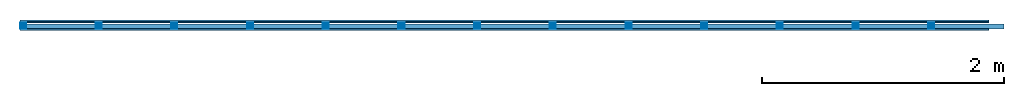
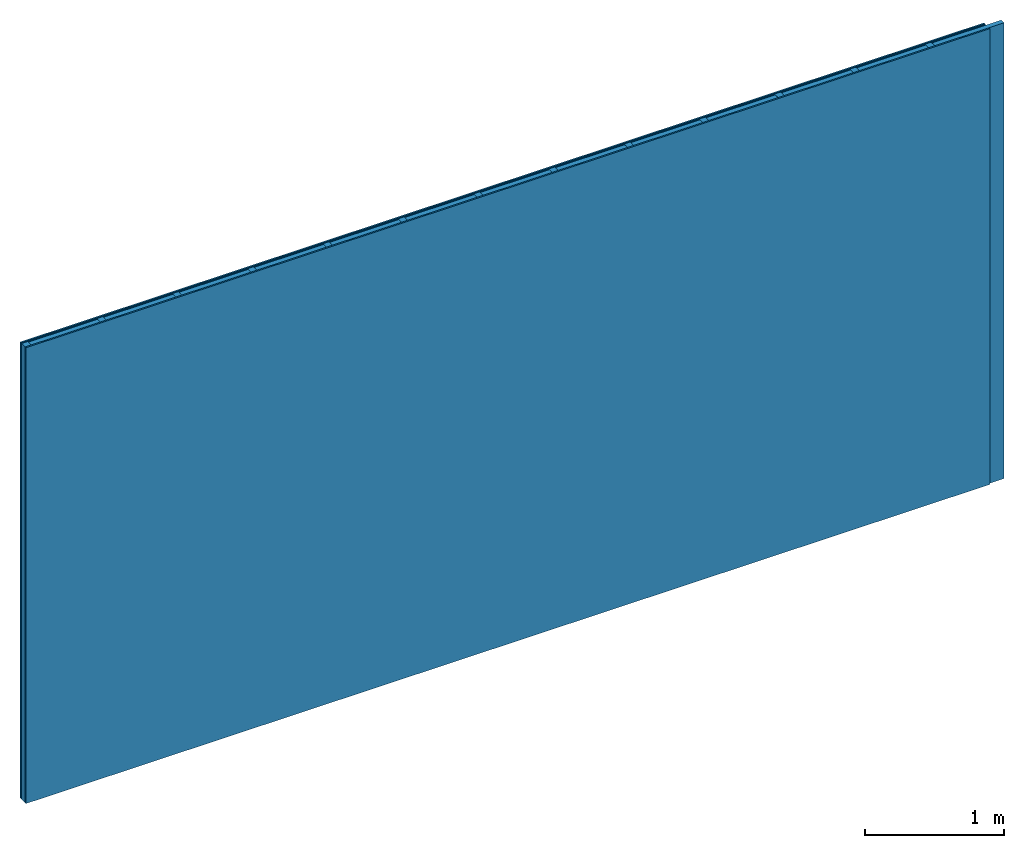
# One storey: 3 plates, 2 members, 1 element without a shape of its own.
"""IFC4 building model written with IfcOpenShell, lengths in metres."""

from ifc_helpers import new_model, si_unit, derived_unit, direction, frame, frame_2d, origin, origin_with_axes, place, context, project, spatial, rectangle, extrude, material, layer, layer_set, type_object, element, aggregate, save


model = new_model("IFC4")

# Units and contexts
plan_context = context("Plan", 3, precision=1e-05, world=origin(), true_north=direction((0.0, 1.0)))
model_context = context("Model", 3, precision=1e-05, world=origin(), true_north=direction((0.0, 1.0)))
ifc_project = project(units=[si_unit("LENGTHUNIT", "METRE"), derived_unit("SOUNDPRESSUREUNIT", [(si_unit("PRESSUREUNIT", "PASCAL", prefix="MICRO"), 0)]), si_unit("ENERGYUNIT", "JOULE", prefix="MEGA"), si_unit("MASSUNIT", "GRAM", prefix="KILO"), derived_unit("THERMALTRANSMITTANCEUNIT", [(si_unit("POWERUNIT", "WATT"), 1), (si_unit("AREAUNIT", "SQUARE_METRE"), -1), (si_unit("THERMODYNAMICTEMPERATUREUNIT", "KELVIN"), -1)]), derived_unit("AREADENSITYUNIT", [(si_unit("MASSUNIT", "GRAM", prefix="KILO"), 1), (si_unit("AREAUNIT", "SQUARE_METRE"), -1)]), derived_unit("USERDEFINED", [(si_unit("ENERGYUNIT", "JOULE", prefix="MEGA"), 1), (si_unit("AREAUNIT", "SQUARE_METRE"), -1)])], contexts=[plan_context, model_context])

# Site, building, storey
site = spatial("IfcSite", under=ifc_project)
building_placement = place(None, origin())
building = spatial("IfcBuilding", under=site, at=building_placement)
storey_placement = place(building_placement, origin())
storey = spatial("IfcBuildingStorey", under=building, at=storey_placement)

# Wall, members, plates
ifc_material_1 = material(Name="joints", Category="04.017")
ifc_layer_1 = layer(ifc_material_1, 0.0, Name="Surface")
ifc_material_2 = material(Name="Plasterboard type A", Category="03.008")
ifc_layer_2 = layer(ifc_material_2, 0.0125, Name="2nd layer")
ifc_material_3 = material(Name="Phone Twin Star", Category="03.013")
ifc_layer_3 = layer(ifc_material_3, 0.01, Name="1st layer")
ifc_material_4 = material(Name="of the art")
ifc_layer_4 = layer(ifc_material_4, 0.0, Name="Bond")
ifc_layer_5 = layer(None, 0.05, Name="Support")
ifc_layer_6 = layer(ifc_material_4, 0.0, Name="Bond")
ifc_layer_7 = layer(ifc_material_2, 0.0125, Name="1st layer")
ifc_layer_8 = layer(ifc_material_1, 0.0, Name="Surface")
ifc_layer_set = layer_set([ifc_layer_1, ifc_layer_2, ifc_layer_3, ifc_layer_4, ifc_layer_5, ifc_layer_6, ifc_layer_7, ifc_layer_8])
wall_type = type_object("IfcWallType", Name="C0457", PredefinedType="NOTDEFINED", material=ifc_layer_set)
wall_placement = place(None, frame((0.0, 0.0, 0.0), z_axis=(0.0, -1.0, 0.0), x_axis=(1.0, 0.0, 0.0)))
wall = element("IfcWall", 1, at=wall_placement, inside=storey, type_object=wall_type, material=ifc_layer_set, Name="Wall #1")
ifc_material_5 = material()
member_1_placement = place(wall_placement, origin())
member_1 = element("IfcMember", 2, at=member_1_placement, material=ifc_material_5, Name="Support", context=plan_context, shape_type="SweptSolid", body=[
    extrude(rectangle(XDim=0.05, YDim=0.05, at=frame_2d((0.025, 0.025), x_axis=(1.0, 0.0))), frame((0.0, 4.0, 0.0225), z_axis=(0.0, -1.0, 0.0), x_axis=(1.0, 0.0, 0.0)), (0.0, 0.0, 1.0), 4.0),
    extrude(rectangle(XDim=0.05, YDim=0.05, at=frame_2d((0.025, 0.025), x_axis=(1.0, 0.0))), frame((0.625, 4.0, 0.0225), z_axis=(0.0, -1.0, 0.0), x_axis=(1.0, 0.0, 0.0)), (0.0, 0.0, 1.0), 4.0),
    extrude(rectangle(XDim=0.05, YDim=0.05, at=frame_2d((0.025, 0.025), x_axis=(1.0, 0.0))), frame((1.25, 4.0, 0.0225), z_axis=(0.0, -1.0, 0.0), x_axis=(1.0, 0.0, 0.0)), (0.0, 0.0, 1.0), 4.0),
    extrude(rectangle(XDim=0.05, YDim=0.05, at=frame_2d((0.025, 0.025), x_axis=(1.0, 0.0))), frame((1.875, 4.0, 0.0225), z_axis=(0.0, -1.0, 0.0), x_axis=(1.0, 0.0, 0.0)), (0.0, 0.0, 1.0), 4.0),
    extrude(rectangle(XDim=0.05, YDim=0.05, at=frame_2d((0.025, 0.025), x_axis=(1.0, 0.0))), frame((2.5, 4.0, 0.0225), z_axis=(0.0, -1.0, 0.0), x_axis=(1.0, 0.0, 0.0)), (0.0, 0.0, 1.0), 4.0),
    extrude(rectangle(XDim=0.05, YDim=0.05, at=frame_2d((0.025, 0.025), x_axis=(1.0, 0.0))), frame((3.125, 4.0, 0.0225), z_axis=(0.0, -1.0, 0.0), x_axis=(1.0, 0.0, 0.0)), (0.0, 0.0, 1.0), 4.0),
    extrude(rectangle(XDim=0.05, YDim=0.05, at=frame_2d((0.025, 0.025), x_axis=(1.0, 0.0))), frame((3.75, 4.0, 0.0225), z_axis=(0.0, -1.0, 0.0), x_axis=(1.0, 0.0, 0.0)), (0.0, 0.0, 1.0), 4.0),
    extrude(rectangle(XDim=0.05, YDim=0.05, at=frame_2d((0.025, 0.025), x_axis=(1.0, 0.0))), frame((4.375, 4.0, 0.0225), z_axis=(0.0, -1.0, 0.0), x_axis=(1.0, 0.0, 0.0)), (0.0, 0.0, 1.0), 4.0),
    extrude(rectangle(XDim=0.05, YDim=0.05, at=frame_2d((0.025, 0.025), x_axis=(1.0, 0.0))), frame((5.0, 4.0, 0.0225), z_axis=(0.0, -1.0, 0.0), x_axis=(1.0, 0.0, 0.0)), (0.0, 0.0, 1.0), 4.0),
    extrude(rectangle(XDim=0.05, YDim=0.05, at=frame_2d((0.025, 0.025), x_axis=(1.0, 0.0))), frame((5.625, 4.0, 0.0225), z_axis=(0.0, -1.0, 0.0), x_axis=(1.0, 0.0, 0.0)), (0.0, 0.0, 1.0), 4.0),
    extrude(rectangle(XDim=0.05, YDim=0.05, at=frame_2d((0.025, 0.025), x_axis=(1.0, 0.0))), frame((6.25, 4.0, 0.0225), z_axis=(0.0, -1.0, 0.0), x_axis=(1.0, 0.0, 0.0)), (0.0, 0.0, 1.0), 4.0),
    extrude(rectangle(XDim=0.05, YDim=0.05, at=frame_2d((0.025, 0.025), x_axis=(1.0, 0.0))), frame((6.875, 4.0, 0.0225), z_axis=(0.0, -1.0, 0.0), x_axis=(1.0, 0.0, 0.0)), (0.0, 0.0, 1.0), 4.0),
    extrude(rectangle(XDim=0.05, YDim=0.05, at=frame_2d((0.025, 0.025), x_axis=(1.0, 0.0))), frame((7.5, 4.0, 0.0225), z_axis=(0.0, -1.0, 0.0), x_axis=(1.0, 0.0, 0.0)), (0.0, 0.0, 1.0), 4.0),
])
ifc_material_6 = material()
member_2_placement = place(wall_placement, origin())
member_2 = element("IfcMember", 3, at=member_2_placement, material=ifc_material_6, Name="Cavity", context=plan_context, shape_type="SweptSolid", body=[
    extrude(rectangle(XDim=0.575, YDim=0.04, at=frame_2d((0.2875, 0.02), x_axis=(1.0, 0.0))), frame((0.05, 4.0, 0.0325), z_axis=(0.0, -1.0, 0.0), x_axis=(1.0, 0.0, 0.0)), (0.0, 0.0, 1.0), 4.0),
    extrude(rectangle(XDim=0.575, YDim=0.04, at=frame_2d((0.2875, 0.02), x_axis=(1.0, 0.0))), frame((0.675, 4.0, 0.0325), z_axis=(0.0, -1.0, 0.0), x_axis=(1.0, 0.0, 0.0)), (0.0, 0.0, 1.0), 4.0),
    extrude(rectangle(XDim=0.575, YDim=0.04, at=frame_2d((0.2875, 0.02), x_axis=(1.0, 0.0))), frame((1.3, 4.0, 0.0325), z_axis=(0.0, -1.0, 0.0), x_axis=(1.0, 0.0, 0.0)), (0.0, 0.0, 1.0), 4.0),
    extrude(rectangle(XDim=0.575, YDim=0.04, at=frame_2d((0.2875, 0.02), x_axis=(1.0, 0.0))), frame((1.925, 4.0, 0.0325), z_axis=(0.0, -1.0, 0.0), x_axis=(1.0, 0.0, 0.0)), (0.0, 0.0, 1.0), 4.0),
    extrude(rectangle(XDim=0.575, YDim=0.04, at=frame_2d((0.2875, 0.02), x_axis=(1.0, 0.0))), frame((2.55, 4.0, 0.0325), z_axis=(0.0, -1.0, 0.0), x_axis=(1.0, 0.0, 0.0)), (0.0, 0.0, 1.0), 4.0),
    extrude(rectangle(XDim=0.575, YDim=0.04, at=frame_2d((0.2875, 0.02), x_axis=(1.0, 0.0))), frame((3.175, 4.0, 0.0325), z_axis=(0.0, -1.0, 0.0), x_axis=(1.0, 0.0, 0.0)), (0.0, 0.0, 1.0), 4.0),
    extrude(rectangle(XDim=0.575, YDim=0.04, at=frame_2d((0.2875, 0.02), x_axis=(1.0, 0.0))), frame((3.8, 4.0, 0.0325), z_axis=(0.0, -1.0, 0.0), x_axis=(1.0, 0.0, 0.0)), (0.0, 0.0, 1.0), 4.0),
    extrude(rectangle(XDim=0.575, YDim=0.04, at=frame_2d((0.2875, 0.02), x_axis=(1.0, 0.0))), frame((4.425, 4.0, 0.0325), z_axis=(0.0, -1.0, 0.0), x_axis=(1.0, 0.0, 0.0)), (0.0, 0.0, 1.0), 4.0),
    extrude(rectangle(XDim=0.575, YDim=0.04, at=frame_2d((0.2875, 0.02), x_axis=(1.0, 0.0))), frame((5.05, 4.0, 0.0325), z_axis=(0.0, -1.0, 0.0), x_axis=(1.0, 0.0, 0.0)), (0.0, 0.0, 1.0), 4.0),
    extrude(rectangle(XDim=0.575, YDim=0.04, at=frame_2d((0.2875, 0.02), x_axis=(1.0, 0.0))), frame((5.675, 4.0, 0.0325), z_axis=(0.0, -1.0, 0.0), x_axis=(1.0, 0.0, 0.0)), (0.0, 0.0, 1.0), 4.0),
    extrude(rectangle(XDim=0.575, YDim=0.04, at=frame_2d((0.2875, 0.02), x_axis=(1.0, 0.0))), frame((6.3, 4.0, 0.0325), z_axis=(0.0, -1.0, 0.0), x_axis=(1.0, 0.0, 0.0)), (0.0, 0.0, 1.0), 4.0),
    extrude(rectangle(XDim=0.575, YDim=0.04, at=frame_2d((0.2875, 0.02), x_axis=(1.0, 0.0))), frame((6.925, 4.0, 0.0325), z_axis=(0.0, -1.0, 0.0), x_axis=(1.0, 0.0, 0.0)), (0.0, 0.0, 1.0), 4.0),
    extrude(rectangle(XDim=0.575, YDim=0.04, at=frame_2d((0.2875, 0.02), x_axis=(1.0, 0.0))), frame((7.55, 4.0, 0.0325), z_axis=(0.0, -1.0, 0.0), x_axis=(1.0, 0.0, 0.0)), (0.0, 0.0, 1.0), 4.0),
])
plate_1_placement = place(wall_placement, origin())
plate_1 = element("IfcPlate", 4, at=plate_1_placement, material=ifc_material_2, Name="2nd layer", context=plan_context, shape_type="SweptSolid", body=[
    extrude(rectangle(XDim=8.0, YDim=4.0, at=frame_2d((4.0, 2.0), x_axis=(1.0, 0.0))), origin_with_axes(), (0.0, 0.0, 1.0), 0.0125),
])
plate_2_placement = place(wall_placement, origin())
plate_2 = element("IfcPlate", 5, at=plate_2_placement, material=ifc_material_3, Name="1st layer", context=plan_context, shape_type="SweptSolid", body=[
    extrude(rectangle(XDim=8.0, YDim=4.0, at=frame_2d((4.0, 2.0), x_axis=(1.0, 0.0))), frame((0.0, 0.0, 0.0125), z_axis=(0.0, 0.0, 1.0), x_axis=(1.0, 0.0, 0.0)), (0.0, 0.0, 1.0), 0.01),
])
plate_3_placement = place(wall_placement, origin())
plate_3 = element("IfcPlate", 6, at=plate_3_placement, material=ifc_material_2, Name="1st layer", context=plan_context, shape_type="SweptSolid", body=[
    extrude(rectangle(XDim=8.0, YDim=4.0, at=frame_2d((4.0, 2.0), x_axis=(1.0, 0.0))), frame((0.0, 0.0, 0.0725), z_axis=(0.0, 0.0, 1.0), x_axis=(1.0, 0.0, 0.0)), (0.0, 0.0, 1.0), 0.0125),
])
aggregate(wall, [plate_1, plate_2, member_1, member_2, plate_3])

save(model, "model.ifc")
